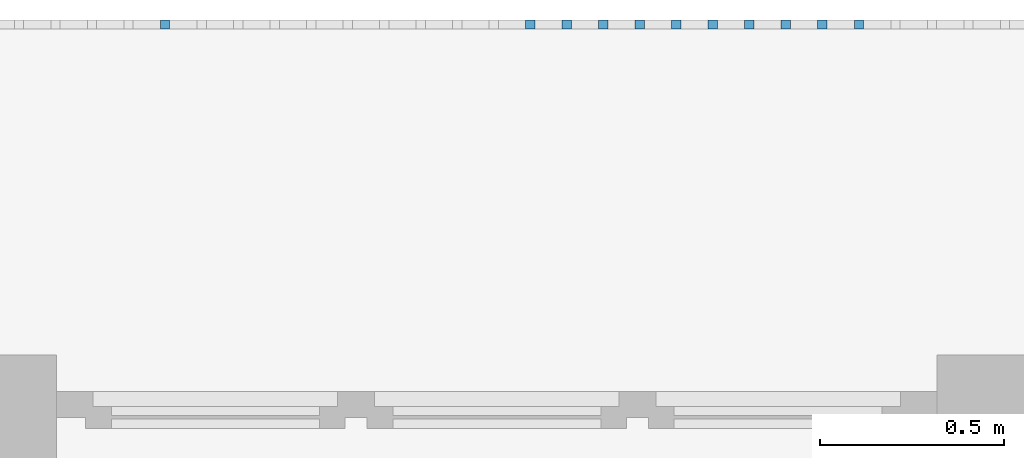
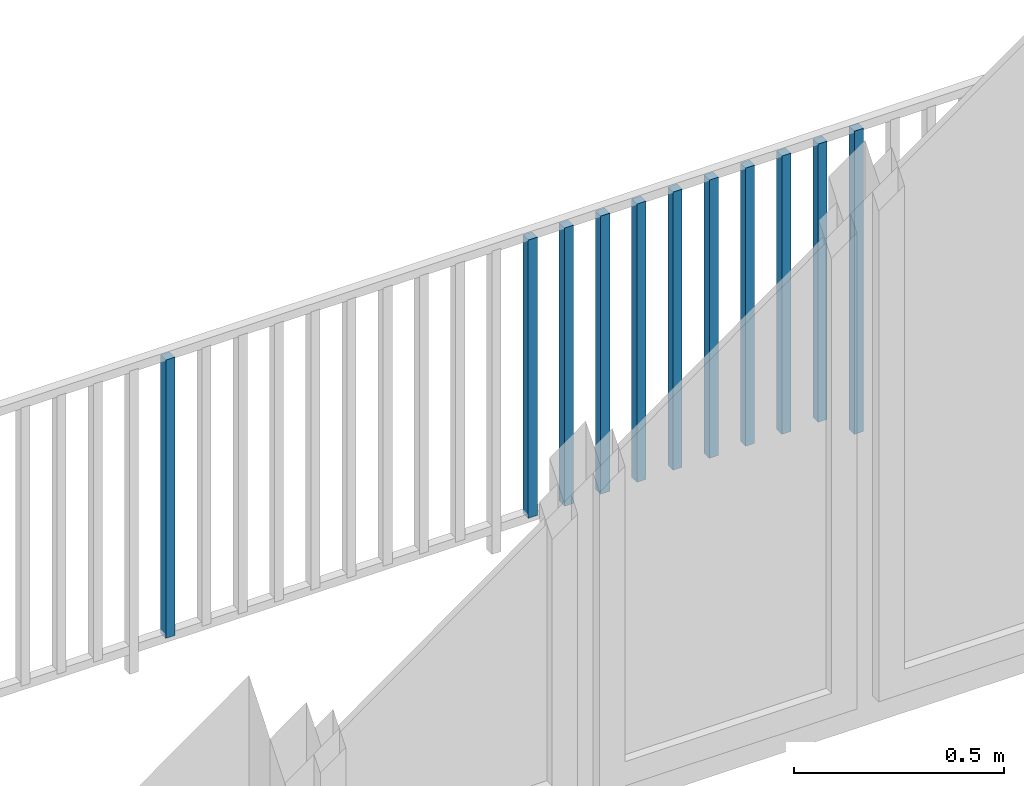
# One storey, part 51 of 54: 11 building element parts, 1 element without a shape of its own.
"""IFC4 building model written with IfcOpenShell, lengths in metres."""

from ifc_helpers import new_model, entity, si_unit, converted_unit, derived_unit, direction, frame, origin_with_axes, place, context, subcontext, project, spatial, polygons, material, type_object, element, aggregate, save


model = new_model("IFC4")

# Units and contexts
model_context = context("Model", 3, precision=1e-05, world=origin_with_axes(), true_north=direction((0.0, 1.0)))
body_context = subcontext(model_context, "Body", "Model", "MODEL_VIEW")
ifc_project = project(units=[si_unit("LENGTHUNIT", "METRE"), si_unit("AREAUNIT", "SQUARE_METRE"), si_unit("VOLUMEUNIT", "CUBIC_METRE"), converted_unit("PLANEANGLEUNIT", "DEGREE", entity("IfcPlaneAngleMeasure", 0.0174532925199), si_unit("PLANEANGLEUNIT", "RADIAN"), dimensions=[0, 0, 0, 0, 0, 0, 0]), converted_unit("TIMEUNIT", "Year", entity("IfcTimeMeasure", 31556926.0), si_unit("TIMEUNIT", "SECOND"), dimensions=[0, 0, 1, 0, 0, 0, 0]), si_unit("MASSUNIT", "GRAM", prefix="KILO"), si_unit("THERMODYNAMICTEMPERATUREUNIT", "DEGREE_CELSIUS"), si_unit("LUMINOUSINTENSITYUNIT", "LUMEN"), si_unit("ENERGYUNIT", "JOULE", prefix="MEGA"), derived_unit("THERMALCONDUCTANCEUNIT", [(si_unit("POWERUNIT", "WATT"), 1), (si_unit("LENGTHUNIT", "METRE"), -1), (si_unit("THERMODYNAMICTEMPERATUREUNIT", "KELVIN"), -1)]), derived_unit("SPECIFICHEATCAPACITYUNIT", [(si_unit("ENERGYUNIT", "JOULE"), 1), (si_unit("MASSUNIT", "GRAM", prefix="KILO"), -1), (si_unit("THERMODYNAMICTEMPERATUREUNIT", "KELVIN"), -1)]), derived_unit("MASSDENSITYUNIT", [(si_unit("MASSUNIT", "GRAM", prefix="KILO"), 1), (si_unit("VOLUMEUNIT", "CUBIC_METRE"), -1)])], contexts=[model_context])

# Site, building, storey, space
site_placement = place(None, origin_with_axes())
site = spatial("IfcSite", under=ifc_project, at=site_placement, CompositionType="ELEMENT")
building_placement = place(site_placement, origin_with_axes())
building = spatial("IfcBuilding", under=site, at=building_placement, CompositionType="ELEMENT")
storey_placement = place(building_placement, frame((0.0, 0.0, 6.29), z_axis=(0.0, 0.0, 1.0), x_axis=(1.0, 0.0, 0.0)))
storey = spatial("IfcBuildingStorey", under=building, at=storey_placement, Name="2. Geschoss", CompositionType="ELEMENT", Elevation=6.29)
space_placement = place(storey_placement, frame((10.2378006196, 9.82118769833, 0.0), z_axis=(0.0, 0.0, 1.0), x_axis=(-1.0, 0.0, 0.0)))
space = spatial("IfcSpace", under=storey, at=space_placement, CompositionType="ELEMENT", PredefinedType="EXTERNAL")

# Railing, building element parts
railing_type = type_object("IfcRailingType", PredefinedType="NOTDEFINED")
railing_placement = place(space_placement, frame((0.0, -7.06315681498e-08, 0.0), z_axis=(0.0, 0.0, 1.0), x_axis=(-1.0, 0.0, 0.0)))
railing = element("IfcRailing", 1, at=railing_placement, inside=space, type_object=railing_type, PredefinedType="NOTDEFINED")
ifc_material = material()
building_element_part_1_placement = place(railing_placement, origin_with_axes())
building_element_part_1 = element("IfcBuildingElementPart", 2, at=building_element_part_1_placement, material=ifc_material, PredefinedType="NOTDEFINED", context=body_context, shape_type="Tessellation", body=[
    polygons([(-6.97597826087, 0.0125, 0.0), (-6.97597826087, -0.0125, 0.0), (-6.97597826087, -0.0125, 0.88), (-6.97597826087, 0.0125, 0.88), (-6.95097826087, 0.0125, 0.0), (-6.95097826087, -0.0125, 0.0), (-6.95097826087, -0.0125, 0.88), (-6.95097826087, 0.0125, 0.88)], [[[1, 2, 3, 4]], [[1, 5, 6, 2]], [[2, 6, 7, 3]], [[4, 3, 7, 8]], [[5, 1, 4, 8]], [[6, 5, 8, 7]]], closed=True),
])
building_element_part_2_placement = place(railing_placement, origin_with_axes())
building_element_part_2 = element("IfcBuildingElementPart", 3, at=building_element_part_2_placement, material=ifc_material, PredefinedType="NOTDEFINED", context=body_context, shape_type="Tessellation", body=[
    polygons([(-7.07545652174, 0.0125, 0.07), (-7.07545652174, -0.0125, 0.07), (-7.07545652174, -0.0125, 0.8775), (-7.07545652174, 0.0125, 0.8775), (-7.05045652174, 0.0125, 0.07), (-7.05045652174, -0.0125, 0.07), (-7.05045652174, -0.0125, 0.8775), (-7.05045652174, 0.0125, 0.8775)], [[[1, 2, 3, 4]], [[1, 5, 6, 2]], [[2, 6, 7, 3]], [[4, 3, 7, 8]], [[5, 1, 4, 8]], [[6, 5, 8, 7]]], closed=True),
])
building_element_part_3_placement = place(railing_placement, origin_with_axes())
building_element_part_3 = element("IfcBuildingElementPart", 4, at=building_element_part_3_placement, material=ifc_material, PredefinedType="NOTDEFINED", context=body_context, shape_type="Tessellation", body=[
    polygons([(-7.17493478261, 0.0125, 0.07), (-7.17493478261, -0.0125, 0.07), (-7.17493478261, -0.0125, 0.8775), (-7.17493478261, 0.0125, 0.8775), (-7.14993478261, 0.0125, 0.07), (-7.14993478261, -0.0125, 0.07), (-7.14993478261, -0.0125, 0.8775), (-7.14993478261, 0.0125, 0.8775)], [[[1, 2, 3, 4]], [[1, 5, 6, 2]], [[2, 6, 7, 3]], [[4, 3, 7, 8]], [[5, 1, 4, 8]], [[6, 5, 8, 7]]], closed=True),
])
building_element_part_4_placement = place(railing_placement, origin_with_axes())
building_element_part_4 = element("IfcBuildingElementPart", 5, at=building_element_part_4_placement, material=ifc_material, PredefinedType="NOTDEFINED", context=body_context, shape_type="Tessellation", body=[
    polygons([(-7.27441304348, 0.0125, 0.07), (-7.27441304348, -0.0125, 0.07), (-7.27441304348, -0.0125, 0.8775), (-7.27441304348, 0.0125, 0.8775), (-7.24941304348, 0.0125, 0.07), (-7.24941304348, -0.0125, 0.07), (-7.24941304348, -0.0125, 0.8775), (-7.24941304348, 0.0125, 0.8775)], [[[1, 2, 3, 4]], [[1, 5, 6, 2]], [[2, 6, 7, 3]], [[4, 3, 7, 8]], [[5, 1, 4, 8]], [[6, 5, 8, 7]]], closed=True),
])
building_element_part_5_placement = place(railing_placement, origin_with_axes())
building_element_part_5 = element("IfcBuildingElementPart", 6, at=building_element_part_5_placement, material=ifc_material, PredefinedType="NOTDEFINED", context=body_context, shape_type="Tessellation", body=[
    polygons([(-7.37389130435, 0.0125, 0.07), (-7.37389130435, -0.0125, 0.07), (-7.37389130435, -0.0125, 0.8775), (-7.37389130435, 0.0125, 0.8775), (-7.34889130435, 0.0125, 0.07), (-7.34889130435, -0.0125, 0.07), (-7.34889130435, -0.0125, 0.8775), (-7.34889130435, 0.0125, 0.8775)], [[[1, 2, 3, 4]], [[1, 5, 6, 2]], [[2, 6, 7, 3]], [[4, 3, 7, 8]], [[5, 1, 4, 8]], [[6, 5, 8, 7]]], closed=True),
])
building_element_part_6_placement = place(railing_placement, origin_with_axes())
building_element_part_6 = element("IfcBuildingElementPart", 7, at=building_element_part_6_placement, material=ifc_material, PredefinedType="NOTDEFINED", context=body_context, shape_type="Tessellation", body=[
    polygons([(-7.47336956522, 0.0125, 0.07), (-7.47336956522, -0.0125, 0.07), (-7.47336956522, -0.0125, 0.8775), (-7.47336956522, 0.0125, 0.8775), (-7.44836956522, 0.0125, 0.07), (-7.44836956522, -0.0125, 0.07), (-7.44836956522, -0.0125, 0.8775), (-7.44836956522, 0.0125, 0.8775)], [[[1, 2, 3, 4]], [[1, 5, 6, 2]], [[2, 6, 7, 3]], [[4, 3, 7, 8]], [[5, 1, 4, 8]], [[6, 5, 8, 7]]], closed=True),
])
building_element_part_7_placement = place(railing_placement, origin_with_axes())
building_element_part_7 = element("IfcBuildingElementPart", 8, at=building_element_part_7_placement, material=ifc_material, PredefinedType="NOTDEFINED", context=body_context, shape_type="Tessellation", body=[
    polygons([(-7.57284782609, 0.0125, 0.07), (-7.57284782609, -0.0125, 0.07), (-7.57284782609, -0.0125, 0.8775), (-7.57284782609, 0.0125, 0.8775), (-7.54784782609, 0.0125, 0.07), (-7.54784782609, -0.0125, 0.07), (-7.54784782609, -0.0125, 0.8775), (-7.54784782609, 0.0125, 0.8775)], [[[1, 2, 3, 4]], [[1, 5, 6, 2]], [[2, 6, 7, 3]], [[4, 3, 7, 8]], [[5, 1, 4, 8]], [[6, 5, 8, 7]]], closed=True),
])
building_element_part_8_placement = place(railing_placement, origin_with_axes())
building_element_part_8 = element("IfcBuildingElementPart", 9, at=building_element_part_8_placement, material=ifc_material, PredefinedType="NOTDEFINED", context=body_context, shape_type="Tessellation", body=[
    polygons([(-7.67232608696, 0.0125, 0.07), (-7.67232608696, -0.0125, 0.07), (-7.67232608696, -0.0125, 0.8775), (-7.67232608696, 0.0125, 0.8775), (-7.64732608696, 0.0125, 0.07), (-7.64732608696, -0.0125, 0.07), (-7.64732608696, -0.0125, 0.8775), (-7.64732608696, 0.0125, 0.8775)], [[[1, 2, 3, 4]], [[1, 5, 6, 2]], [[2, 6, 7, 3]], [[4, 3, 7, 8]], [[5, 1, 4, 8]], [[6, 5, 8, 7]]], closed=True),
])
building_element_part_9_placement = place(railing_placement, origin_with_axes())
building_element_part_9 = element("IfcBuildingElementPart", 10, at=building_element_part_9_placement, material=ifc_material, PredefinedType="NOTDEFINED", context=body_context, shape_type="Tessellation", body=[
    polygons([(-7.77180434783, 0.0125, 0.07), (-7.77180434783, -0.0125, 0.07), (-7.77180434783, -0.0125, 0.8775), (-7.77180434783, 0.0125, 0.8775), (-7.74680434783, 0.0125, 0.07), (-7.74680434783, -0.0125, 0.07), (-7.74680434783, -0.0125, 0.8775), (-7.74680434783, 0.0125, 0.8775)], [[[1, 2, 3, 4]], [[1, 5, 6, 2]], [[2, 6, 7, 3]], [[4, 3, 7, 8]], [[5, 1, 4, 8]], [[6, 5, 8, 7]]], closed=True),
])
building_element_part_10_placement = place(railing_placement, origin_with_axes())
building_element_part_10 = element("IfcBuildingElementPart", 11, at=building_element_part_10_placement, material=ifc_material, PredefinedType="NOTDEFINED", context=body_context, shape_type="Tessellation", body=[
    polygons([(-7.8712826087, 0.0125, 0.07), (-7.8712826087, -0.0125, 0.07), (-7.8712826087, -0.0125, 0.8775), (-7.8712826087, 0.0125, 0.8775), (-7.8462826087, 0.0125, 0.07), (-7.8462826087, -0.0125, 0.07), (-7.8462826087, -0.0125, 0.8775), (-7.8462826087, 0.0125, 0.8775)], [[[1, 2, 3, 4]], [[1, 5, 6, 2]], [[2, 6, 7, 3]], [[4, 3, 7, 8]], [[5, 1, 4, 8]], [[6, 5, 8, 7]]], closed=True),
])
building_element_part_11_placement = place(railing_placement, origin_with_axes())
building_element_part_11 = element("IfcBuildingElementPart", 12, at=building_element_part_11_placement, material=ifc_material, PredefinedType="NOTDEFINED", context=body_context, shape_type="Tessellation", body=[
    polygons([(-8.86606521739, 0.0125, 0.07), (-8.86606521739, -0.0125, 0.07), (-8.86606521739, -0.0125, 0.8775), (-8.86606521739, 0.0125, 0.8775), (-8.84106521739, 0.0125, 0.07), (-8.84106521739, -0.0125, 0.07), (-8.84106521739, -0.0125, 0.8775), (-8.84106521739, 0.0125, 0.8775)], [[[1, 2, 3, 4]], [[1, 5, 6, 2]], [[2, 6, 7, 3]], [[4, 3, 7, 8]], [[5, 1, 4, 8]], [[6, 5, 8, 7]]], closed=True),
])
aggregate(railing, [building_element_part_1, building_element_part_2, building_element_part_3, building_element_part_4, building_element_part_5, building_element_part_6, building_element_part_7, building_element_part_8, building_element_part_9, building_element_part_10, building_element_part_11])

save(model, "model.ifc")
